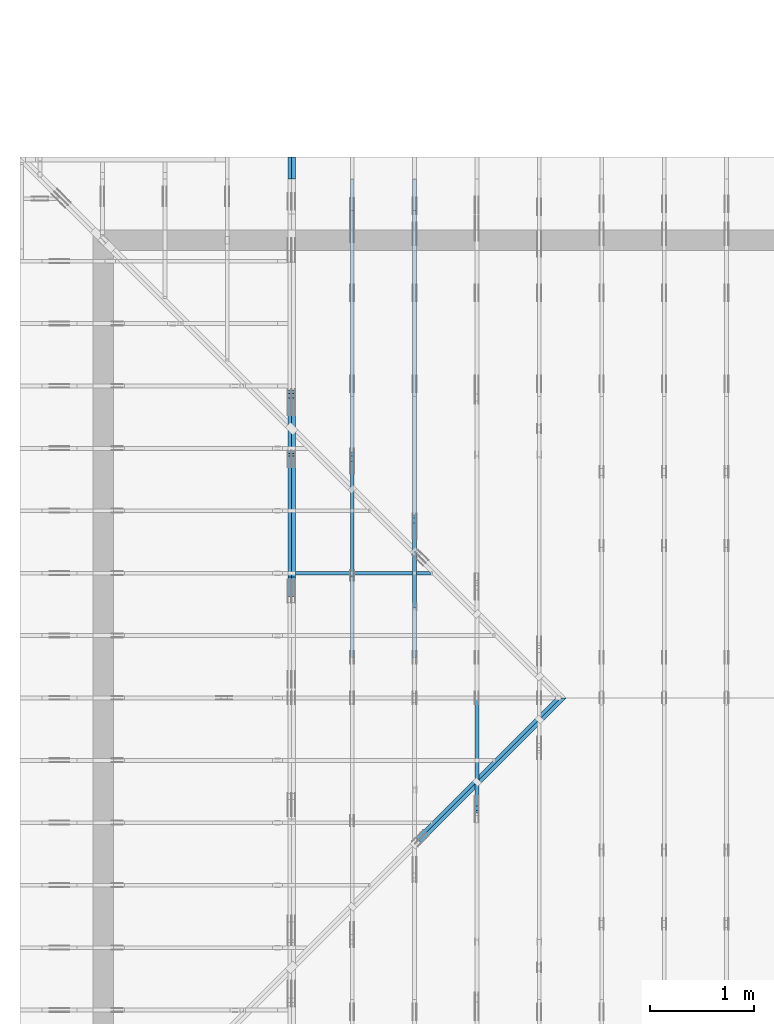
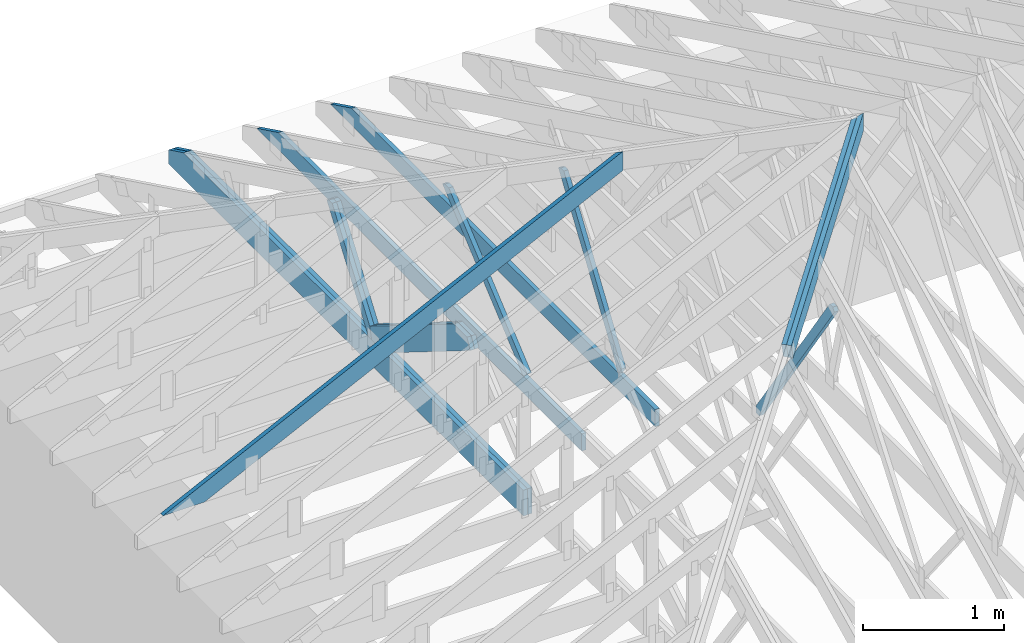
# One storey, part 8 of 159: 14 members, 6 elements without a shape of their own.
"""IFC2X3 building model written with IfcOpenShell, lengths in millimetres."""

from ifc_helpers import new_model, si_unit, frame, origin, origin_with_axes, origin_2d, place, context, project, spatial, faceted_brep, element, aggregate, save


model = new_model("IFC2X3")

# Units and contexts
model_context = context("Model", 3, precision=1e-05, world=origin())
plan_context = context("Plan", 2, precision=1e-05, world=origin_2d())
ifc_project = project(units=[si_unit("LENGTHUNIT", "METRE", prefix="MILLI"), si_unit("AREAUNIT", "SQUARE_METRE"), si_unit("VOLUMEUNIT", "CUBIC_METRE"), si_unit("SOLIDANGLEUNIT", "STERADIAN"), si_unit("PLANEANGLEUNIT", "RADIAN"), si_unit("MASSUNIT", "GRAM"), si_unit("TIMEUNIT", "SECOND"), si_unit("THERMODYNAMICTEMPERATUREUNIT", "DEGREE_CELSIUS"), si_unit("LUMINOUSINTENSITYUNIT", "LUMEN")], contexts=[model_context, plan_context])

# Site, building, storey
site_placement = place(None, origin_with_axes())
site = spatial("IfcSite", under=ifc_project, at=site_placement, CompositionType="ELEMENT")
building_placement = place(site_placement, origin_with_axes())
building = spatial("IfcBuilding", under=site, at=building_placement, Name="Plan 1", CompositionType="ELEMENT")
storey_placement = place(building_placement, origin_with_axes())
storey = spatial("IfcBuildingStorey", under=building, at=storey_placement, Name="Etasje 1", CompositionType="ELEMENT", Elevation=0.0)

# Assembly, member
assembly_1_placement = place(storey_placement, frame((-700.000000000007, 5681.993668449246, 1.1021457184401395e-15), z_axis=(0.0, -1.0, 6.123031769111886e-17), x_axis=(1.0, 0.0, 0.0)))
assembly_1 = element("IfcElementAssembly", 1, at=assembly_1_placement, inside=storey, Name="S3 (13)", AssemblyPlace="FACTORY", PredefinedType="TRUSS")
member_1_placement = place(assembly_1_placement, frame((276.0602225691233, 89.97847976265317, -36.00000021758854), z_axis=(0.0, 0.0, 1.0), x_axis=(0.898794046299167, 0.4383711467890774, 0.0)))
member_1 = element("IfcMember", 2, at=member_1_placement, Name="S3-O20", context=model_context, shape_type="Brep", body=[
    faceted_brep([(4178.836482823229, 147.99999481742884, 36.00000324779785), (4106.652058872152, 7.195239959401079e-10, 36.000000217589104), (4066.5983889296263, 3.219023483325145e-07, 6.821210263296962e-13), (4138.782812880701, 147.99999513861133, 3.03020965475298e-06), (5.61982989779608e-05, 147.99999999999778, 2.175885427391222e-07), (5.61982989779608e-05, 147.99999999999778, 36.00000021758854), (4178.836481979549, 147.99999999999753, 36.00000021758854), (4138.782813003719, 147.99999999999753, 2.175885427391222e-07), (9.727869428388658e-05, 148.0000000002397, 2.1758854273913412e-07), (4138.782812122445, 148.0000000002397, 2.1758904957709508e-07), (4066.5983867684413, 0.0, 2.175890407373445e-07), (303.44492149744434, 0.0, 2.175885798991801e-07), (303.4449717131312, 9.140421752817929e-11, 2.175885427391222e-07), (303.4449717131312, 9.140421752817929e-11, 36.00000021758854), (1.4210854715202004e-14, 148.00000154103162, 36.00000021758854), (1.4210854715202004e-14, 148.00000154103162, 2.175885427391222e-07), (4106.652057990875, 7.120212294089205e-10, 36.00000021758854), (303.44506870254423, 7.127198441255181e-10, 36.00000021758854), (303.44506870254423, 7.127176398340812e-10, 2.175885427391222e-07), (4066.598389015045, 7.120263826141119e-10, 2.175885427391222e-07), (4178.836484226156, 148.00000000071918, 36.00000021758854), (0.00020340340273605761, 148.00000000071918, 36.00000021758854), (303.4450276221526, 9.157474778476171e-11, 36.00000021758854), (4106.652058872153, 9.157474778476171e-11, 36.00000021758854)], [[[0, 1, 2, 3]], [[4, 5, 6, 7]], [[8, 9, 10, 11]], [[12, 13, 14, 15]], [[16, 17, 18, 19]], [[20, 21, 22, 23]]]),
])
aggregate(assembly_1, [member_1])

# Assembly, members
assembly_2_placement = place(storey_placement, frame((-674.5441558772914, -725.4547742521996, 2.204291436880279e-15), z_axis=(0.7071067811865475, -0.7071067811865476, 6.123031769111886e-17), x_axis=(0.7071067811865476, 0.7071067811865475, 0.0)))
assembly_2 = element("IfcElementAssembly", 3, at=assembly_2_placement, inside=storey, Name="GR1 (8)", AssemblyPlace="FACTORY", PredefinedType="TRUSS")
member_2_placement = place(assembly_2_placement, frame((5468.9344725271785, 1837.1506716808092, -36.00000195234122), z_axis=(0.0, 0.0, 1.0), x_axis=(0.9453579955214152, 0.32603413978252627, 0.0)))
member_2 = element("IfcMember", 4, at=member_2_placement, Name="GR1-O54.1", context=model_context, shape_type="Brep", body=[
    faceted_brep([(2083.0503962585176, 147.99999855201952, 36.00000161316632), (2032.0083021287878, 2.5398867364856414e-07, 36.00000195234111), (1993.9274905929392, 0.0, 2.3741075665384415e-06), (2044.9695847226685, 147.99999467122797, 3.217394123566919e-06), (0.00010423591174912872, 148.00000025499548, 1.952341222022369e-06), (0.00010423591174912872, 148.00000025499548, 36.00000195234122), (2083.0503972046617, 148.00000025499534, 36.00000195234122), (2044.9695866577858, 148.00000025499537, 1.952341222022369e-06), (0.00010288836620020447, 148.0000002568056, 1.9523412220223817e-06), (2044.969585310242, 148.0000002568056, 1.952341472450644e-06), (1993.927490125916, 2.550277713453397e-07, 1.9523414661999965e-06), (0.00010288836710969917, 2.550277713453397e-07, 1.9523412220223817e-06), (5.1431408792268485e-05, 6.324755759123946e-07, 1.8783537143463036e-06), (5.143140788320172e-05, 6.324755759123946e-07, 36.00000195234122), (5.143140790132588e-05, 148.000003407725, 36.00000255341424), (5.1431408810392706e-05, 148.000003407725, 4.576700956714107e-28), (2032.008300781249, 2.540408259103419e-07, 36.00000195234122), (4.049084566054305e-31, 2.540411991718833e-07, 36.00000195234122), (6.465218929522581e-38, 2.5404119696759185e-07, 1.952341222022369e-06), (1993.927490234374, 2.540408307011508e-07, 1.952341222022369e-06), (2083.0503973131126, 148.00000025398867, 36.00000195234122), (1.3475364539772272e-06, 148.00000025398867, 36.00000195234122), (1.3475364539772272e-06, 2.5680515136627946e-07, 36.00000195234122), (2032.0083021287874, 2.5680515136627946e-07, 36.00000195234122)], [[[0, 1, 2, 3]], [[4, 5, 6, 7]], [[8, 9, 10, 11]], [[12, 13, 14, 15]], [[16, 17, 18, 19]], [[20, 21, 22, 23]]]),
])
member_3_placement = place(assembly_2_placement, frame((5468.934471253672, 1837.1506712415073, -72.00000195234122), z_axis=(0.0, 0.0, 1.0), x_axis=(0.9453579955214152, 0.32603413978252627, 0.0)))
member_3 = element("IfcMember", 5, at=member_3_placement, Name="GR1-O54.1", context=model_context, shape_type="Brep", body=[
    faceted_brep([(2044.969585711107, 147.99999855221392, 36.00000161290052), (1993.9274915815217, 2.5413226012460655e-07, 36.00000195234111), (1955.846680045794, -5.684341886080802e-14, 2.3739810330880573e-06), (2006.8887741753783, 147.99999467127776, 3.2170017902899417e-06), (0.00010423551429994404, 148.00000025511963, 1.952341222022369e-06), (0.00010423551429994404, 148.00000025511918, 36.00000195234122), (2044.9695866573893, 148.00000025511903, 36.00000195234122), (2006.8887761105143, 148.00000025511952, 1.952341222022369e-06), (0.00010288836074323626, 148.00000025689633, 1.9523412220223817e-06), (2006.8887747633617, 148.00000025689633, 1.9523414677872435e-06), (1955.8466795790346, 2.551523721194826e-07, 1.952341461536596e-06), (0.00010288836165273096, 2.551523721194826e-07, 1.9523412220223817e-06), (5.277855598251335e-05, 6.325665253825719e-07, 1.8783537143463036e-06), (5.2778555073446586e-05, 6.325665253825719e-07, 36.00000195234122), (5.2778555091570747e-05, 148.00000340781594, 36.00000255341424), (5.2778556000637575e-05, 148.00000340781594, 4.576700956714107e-28), (1993.927490234376, 2.5418498781567277e-07, 36.00000195234122), (9.094947017729282e-13, 2.541853540821138e-07, 36.00000195234122), (9.094947017729282e-13, 2.541853518778224e-07, 1.952341222022369e-06), (1955.846679687501, 2.5418499260648175e-07, 1.952341222022369e-06), (2044.9695867658475, 148.00000025413283, 36.00000195234122), (1.3471462807501666e-06, 148.00000025413283, 36.00000195234122), (1.3471462807501666e-06, 2.5689610083645675e-07, 36.00000195234122), (1993.9274915815213, 2.5689610083645675e-07, 36.00000195234122)], [[[0, 1, 2, 3]], [[4, 5, 6, 7]], [[8, 9, 10, 11]], [[12, 13, 14, 15]], [[16, 17, 18, 19]], [[20, 21, 22, 23]]]),
])
aggregate(assembly_2, [member_2, member_3])

# Assembly, member
assembly_3_placement = place(storey_placement, frame((3675.02226140475, 9699.999999999993, 1.1021457184401395e-15), z_axis=(-1.0, 1.836909530733566e-16, 6.123031769111886e-17), x_axis=(-1.836909530733566e-16, -1.0, 0.0)))
assembly_3 = element("IfcElementAssembly", 6, at=assembly_3_placement, inside=storey, Name="V4 (5)", AssemblyPlace="FACTORY", PredefinedType="TRUSS")
member_4_placement = place(assembly_3_placement, frame((6252.472090234662, 1961.8934703465848, -36.00000000000001), z_axis=(0.0, 0.0, 1.0), x_axis=(-0.567606162978192, -0.8233002148361037, 0.0)))
member_4 = element("IfcMember", 7, at=member_4_placement, Name="V4-D17", context=model_context, shape_type="Brep", body=[
    faceted_brep([(1882.0088922396953, 72.99981526764714, 36.0), (11.925045841840074, 72.99981526764714, 36.0), (1.7729007595335133e-06, 36.49989538157706, 36.0), (25.163967382082774, 0.00011852315719806938, 36.0), (1854.2304179382295, 0.00011852315719806938, 36.0), (1907.1728578488774, 36.49989538157706, 36.0), (11.925045841840074, 72.99981526764714, 1.4603486907540475e-15), (1882.0088922396953, 72.99981526764714, 2.3047200473869444e-13), (1907.1728578488774, 36.49989538157706, 2.335535999559317e-13), (1854.2304179382295, 0.00011852315719806938, 2.270702351257878e-13), (25.163967382082774, 0.00011852315719806938, 3.0815954343477618e-15), (1.7729007595335133e-06, 36.49989538157706, 2.171105534821259e-22), (-3.552713678800501e-15, 36.50000000000729, 3.0412819459963817e-31), (-1.7763568394002505e-15, 36.50000000000729, 36.0), (11.924987637653432, 72.9999999999991, 36.0), (11.924987637653429, 72.9999999999991, 5.210607437362237e-31), (25.164119449224014, -3.552713678800501e-15, 3.944304526105059e-31), (25.164119449224017, -1.7763568394002505e-15, 36.0), (1.4210854715202004e-14, 36.50000000000728, 36.0), (1.0658141036401503e-14, 36.50000000000728, -7.888609052210118e-31), (1854.2304397233015, 1.2875129933782132e-12, 4.698144675927301e-30), (1854.2304397233015, 1.2897172848150934e-12, 36.0), (25.164119449224017, 1.1629865528625666e-15, 36.0), (25.164119449224017, -1.0413048840177125e-15, 6.375942886171814e-32), (1907.1728843292735, 36.499999999997385, 3.7865323450608567e-29), (1907.1728843292735, 36.499999999997385, 36.0), (1854.230439723302, 6.821210263296962e-13, 36.0), (1854.230439723302, 6.821210263296962e-13, 3.7865323450608567e-29), (1882.0087648800502, 73.00000000000159, -1.9030413559702196e-29), (1882.0087648800502, 73.00000000000159, 36.0), (1907.172884329273, 36.49999999999784, 36.0), (1907.172884329273, 36.49999999999784, -1.8757185624799696e-29), (11.92498763765343, 72.99999999999909, 0.0), (11.92498763765343, 72.99999999999909, 36.0), (1882.0087648800504, 73.00000000000189, 36.0), (1882.0087648800504, 73.00000000000189, 3.944304526105059e-30)], [[[0, 1, 2, 3, 4, 5]], [[6, 7, 8, 9, 10, 11]], [[12, 13, 14, 15]], [[16, 17, 18, 19]], [[20, 21, 22, 23]], [[24, 25, 26, 27]], [[28, 29, 30, 31]], [[32, 33, 34, 35]]]),
])
aggregate(assembly_3, [member_4])

# Assembly, members
assembly_4_placement = place(storey_placement, frame((3075.02226140475, 9699.999999999993, 1.1021457184401395e-15), z_axis=(-1.0, 1.836909530733566e-16, 6.123031769111886e-17), x_axis=(-1.836909530733566e-16, -1.0, 0.0)))
assembly_4 = element("IfcElementAssembly", 8, at=assembly_4_placement, inside=storey, Name="V3 (4)", AssemblyPlace="FACTORY", PredefinedType="TRUSS")
member_5_placement = place(assembly_4_placement, frame((4808.81787109375, 371.00000000000045, -36.0), z_axis=(0.0, 0.0, 1.0), x_axis=(-1.0, 1.2246063538223773e-16, 0.0)))
member_5 = element("IfcMember", 9, at=member_5_placement, Name="V3-U35", context=model_context, shape_type="Brep", body=[
    faceted_brep([(4597.636581420898, 148.000000000001, 36.0), (0.0, 148.000000000001, 36.0), (0.0, 4.547473508864641e-13, 36.0), (4294.191589355469, 4.547473508864641e-13, 36.0), (0.0, 148.000000000001, 0.0), (4597.636581420898, 148.000000000001, 5.630294970174226e-13), (4294.191589355469, 4.547473508864641e-13, 5.25869430485532e-13), (0.0, 4.547473508864641e-13, 0.0), (0.00023664720265514916, 0.0, 0.0), (0.00023664720265735345, -2.6993892992798474e-31, 36.0), (0.00023664720267547762, 147.99999999999997, 36.0), (0.00023664720267327333, 147.99999999999997, -1.1097479173457682e-30), (4294.191606856883, -7.888042021967641e-13, 1.0746792202003985e-28), (4294.191606856883, -7.865999107598839e-13, 36.0), (0.00023664720265514916, 2.2041947133152905e-15, 36.0), (0.00023664720265514916, -9.672356498864107e-20, 5.922414612472074e-36), (4597.636575412006, 148.00000000000205, -2.5243548967072372e-29), (4597.636575412006, 148.00000000000205, 36.0), (4294.191606856883, 1.5916157281026244e-12, 36.0), (4294.191606856883, 1.5916157281026244e-12, -2.5243548967072372e-29), (0.00023664720265514916, 147.99999999999997, 0.0), (0.00023664720265514916, 147.99999999999997, 36.0), (4597.636575412005, 148.0000000000007, 36.0), (4597.636575412005, 148.0000000000007, -1.735493991486226e-29)], [[[0, 1, 2, 3]], [[4, 5, 6, 7]], [[8, 9, 10, 11]], [[12, 13, 14, 15]], [[16, 17, 18, 19]], [[20, 21, 22, 23]]]),
])
member_6_placement = place(assembly_4_placement, frame((3438.4424404888405, 1632.3753621443234, -35.99999999999999), z_axis=(0.0, 0.0, 1.0), x_axis=(0.5603073033844749, -0.8282848095757992, 0.0)))
member_6 = element("IfcMember", 10, at=member_6_placement, Name="V3-D30", context=model_context, shape_type="Brep", body=[
    faceted_brep([(1493.610833894492, 73.00034285986249, 36.0), (29.87093653177908, 73.00034285986249, 36.0), (5.179933688446226, 36.500243712163865, 36.0), (0.0, 0.0002251209748465044, 36.0), (1522.8763675991224, 0.0002251209748465044, 36.0), (29.87093653177908, 73.00034285986249, 3.658013867144162e-15), (1493.610833894492, 73.00034285986249, 1.8290853173251343e-13), (1522.8763675991224, 0.0002251209748465044, 1.8649240758478276e-13), (0.0, 0.0002251209748465044, 0.0), (5.179933688446226, 36.500243712163865, 6.343379707249831e-16), (5.179846854619438, 36.50018205388142, -3.944304526105059e-31), (5.179846854619441, 36.50018205388142, 36.0), (29.870890727174366, 73.000182051514, 36.0), (29.870890727174366, 73.000182051514, -5.9164567891575885e-31), (4.145090724708039e-05, 0.00018205151400251988, -1.651522543131281e-33), (4.145090724926282e-05, 0.00018205151400221017, 36.0), (5.1798468546194325, 36.50018205388142, 36.0), (5.179846854619431, 36.50018205388142, -2.564377601742566e-31), (1522.876490750957, 0.00018205151507537097, 4.568651442233575e-29), (1522.876490750957, 0.00018205151507757526, 36.0), (4.145090724705369e-05, 0.00018205151400472788, 36.0), (4.145090724705369e-05, 0.0001820515140025236, 1.504632769052528e-36), (1493.6107231272665, 73.00018205151548, 1.5038639598628418e-30), (1493.6107231272665, 73.00018205151548, 36.0), (1522.876490750957, 0.00018205151593519986, 36.0), (1522.876490750957, 0.00018205151593519986, 1.7462163754190554e-30), (29.87089072717436, 73.000182051514, 0.0), (29.87089072717436, 73.000182051514, 36.0), (1493.6107231272665, 73.00018205151554, 36.0), (1493.6107231272665, 73.00018205151554, 1.1044052673094165e-29)], [[[0, 1, 2, 3, 4]], [[5, 6, 7, 8, 9]], [[10, 11, 12, 13]], [[14, 15, 16, 17]], [[18, 19, 20, 21]], [[22, 23, 24, 25]], [[26, 27, 28, 29]]]),
])
aggregate(assembly_4, [member_5, member_6])

assembly_5_placement = place(storey_placement, frame((2475.02226140475, 9699.999999999993, 1.1021457184401395e-15), z_axis=(-1.0, 1.836909530733566e-16, 6.123031769111886e-17), x_axis=(-1.836909530733566e-16, -1.0, 0.0)))
assembly_5 = element("IfcElementAssembly", 11, at=assembly_5_placement, inside=storey, Name="V2 (3)", AssemblyPlace="FACTORY", PredefinedType="TRUSS")
member_7_placement = place(assembly_5_placement, frame((4808.81787109375, 371.0, -36.0), z_axis=(0.0, 0.0, 1.0), x_axis=(-1.0, 1.2246063538223773e-16, 0.0)))
member_7 = element("IfcMember", 12, at=member_7_placement, Name="V2-U35", context=model_context, shape_type="Brep", body=[
    faceted_brep([(4597.636581420898, 148.00000000000054, 36.0), (0.0, 148.00000000000054, 36.0), (0.0, 0.0, 36.0), (4294.191589355469, 0.0, 36.0), (0.0, 148.00000000000054, 0.0), (4597.636581420898, 148.00000000000054, 5.630294970174226e-13), (4294.191589355469, 0.0, 5.25869430485532e-13), (0.0, 0.0, 0.0), (0.00023664720356464386, 0.0, 0.0), (0.00023664720356684815, -2.6993892992798474e-31, 36.0), (0.00023664720358497233, 147.99999999999997, 36.0), (0.00023664720358276803, 147.99999999999997, -1.1097479173457682e-30), (4294.191606856883, -7.888041771362396e-13, 7.962359572160306e-29), (4294.191606856883, -7.865998856993593e-13, 36.0), (0.00023664720356464386, 2.2042197738396225e-15, 36.0), (0.00023664720356464386, -7.166304065663759e-20, 4.387950746117487e-36), (4597.636575412005, 148.0000000000009, -2.5243548967072372e-29), (4597.636575412005, 148.0000000000009, 36.0), (4294.191606856883, 9.094947017729282e-13, 36.0), (4294.191606856883, 9.094947017729282e-13, -2.5243548967072372e-29), (0.00023664720356464386, 147.99999999999997, 0.0), (0.00023664720356464386, 147.99999999999997, 36.0), (4597.636575412005, 148.0000000000007, 36.0), (4597.636575412005, 148.0000000000007, 1.1044052673094165e-29)], [[[0, 1, 2, 3]], [[4, 5, 6, 7]], [[8, 9, 10, 11]], [[12, 13, 14, 15]], [[16, 17, 18, 19]], [[20, 21, 22, 23]]]),
])
member_8_placement = place(assembly_5_placement, frame((2835.7304687500005, 1338.4130859375, -36.00000000000001), z_axis=(0.0, 0.0, 1.0), x_axis=(0.7634525540161362, -0.6458639158261117, 0.0)))
member_8 = element("IfcMember", 13, at=member_8_placement, Name="V2-D31", context=model_context, shape_type="Brep", body=[
    faceted_brep([(1510.1262624601582, 73.00006736832302, 36.0), (59.22069243180658, 73.00006736832302, 36.0), (16.075371691791588, 36.5001661737283, 36.0), (0.0, 0.0, 36.0), (1497.8591223631006, 0.0, 36.0), (59.22069243180658, 73.00006736832302, 7.252203622975112e-15), (1510.1262624601582, 73.00006736832302, 1.8493102160827485e-13), (1497.8591223631006, 0.0, 1.8342877983766626e-13), (0.0, 0.0, 0.0), (16.075371691791588, 36.5001661737283, 1.9686002313824358e-15), (16.0752887080489, 36.5001098598309, 0.0), (16.0752887080489, 36.5001098598309, 36.0), (59.22062867497106, 73.00010985864765, 36.0), (59.22062867497106, 73.00010985864765, 3.944304526105059e-31), (5.931443138357624e-05, 0.00010985864719212936, -7.081601879689162e-32), (5.9314431385593556e-05, 0.0001098586471912409, 36.0), (16.075288708048877, 36.50010985983091, 36.0), (16.075288708048873, 36.50010985983091, 1.5062443203767112e-30), (1497.8591404537046, 0.00010985864558708625, 1.4772869712546597e-29), (1497.8591404537046, 0.00010985864558929054, 36.0), (5.93144313825178e-05, 0.0001098586471947998, 36.0), (5.93144313825178e-05, 0.00010985864719259551, 7.52316384526264e-37), (1510.1262905414742, 73.0001098586458, -1.2621774483536186e-29), (1510.1262905414742, 73.0001098586458, 36.0), (1497.8591404537046, 0.00010985864579993176, 36.0), (1497.8591404537046, 0.00010985864579993176, -1.2621774483536186e-29), (59.22062867497107, 73.00010985864765, 7.888609052210118e-31), (59.22062867497107, 73.00010985864765, 36.0), (1510.1262905414742, 73.00010985864594, 36.0), (1510.1262905414742, 73.00010985864596, 7.888609052210118e-30)], [[[0, 1, 2, 3, 4]], [[5, 6, 7, 8, 9]], [[10, 11, 12, 13]], [[14, 15, 16, 17]], [[18, 19, 20, 21]], [[22, 23, 24, 25]], [[26, 27, 28, 29]]]),
])
aggregate(assembly_5, [member_7, member_8])

assembly_6_placement = place(storey_placement, frame((1875.0222614047502, 9699.999999999993, 0.0), z_axis=(-1.0, 1.836909530733566e-16, 6.123031769111886e-17), x_axis=(-1.836909530733566e-16, -1.0, 0.0)))
assembly_6 = element("IfcElementAssembly", 14, at=assembly_6_placement, inside=storey, Name="V1 (2)", AssemblyPlace="FACTORY", PredefinedType="TRUSS")
member_9_placement = place(assembly_6_placement, frame((5019.9990234375, 223.00000000093073, -36.0), z_axis=(0.0, 0.0, 1.0), x_axis=(-1.0, 1.2246063538223773e-16, 0.0)))
member_9 = element("IfcMember", 15, at=member_9_placement, Name="V1-U4", context=model_context, shape_type="Brep", body=[
    faceted_brep([(5019.9990234375, 223.00000000093135, 36.0), (0.0, 223.00000000093135, 36.0), (0.0, 9.3072571871744e-10, 36.0), (4808.817733764648, 9.3072571871744e-10, 36.0), (5019.999023437502, 103.00000000093135, 36.0), (0.0, 223.00000000093135, 0.0), (5019.9990234375, 223.00000000093135, 6.147522700283691e-13), (5019.999023437502, 103.00000000093135, 6.147522700283693e-13), (4808.817733764648, 9.3072571871744e-10, 5.888908751141913e-13), (0.0, 9.3072571871744e-10, 0.0), (0.00012207031977595761, 9.306972970080096e-10, 0.0), (0.0001220703197781619, 9.306972970080096e-10, 36.0), (0.00012207031980547063, 223.00000000093073, 36.0), (0.00012207031980326634, 223.00000000093073, -1.67212096573961e-30), (4808.8177277538925, -1.2832280317029862e-12, 7.857246005132692e-29), (4808.8177277538925, -1.281023740266106e-12, 36.0), (0.00012207031977595761, 9.306995012668721e-10, 36.0), (0.00012207031977595761, 9.306972969754353e-10, 1.994540702744352e-36), (5019.9990234375, 103.0000000007442, -1.3741865306144549e-28), (5019.9990234375, 103.0000000007442, 36.0), (4808.817727753891, 2.0463630789890885e-12, 36.0), (4808.817727753891, 2.0463630789890885e-12, -1.381426816777479e-28), (5019.999023437504, 223.00000000093135, 2.0194839173657902e-28), (5019.999023437504, 223.00000000093135, 36.0), (5019.999023437504, 103.00000000074218, 36.0), (5019.999023437504, 103.00000000074218, 1.0097419586828951e-28), (0.00012207031977595761, 223.00000000093073, 0.0), (0.00012207031977595761, 223.00000000093073, 36.0), (5019.9990234375, 223.00000000093152, 36.0), (5019.9990234375, 223.00000000093152, 1.1044052673094165e-29)], [[[0, 1, 2, 3, 4]], [[5, 6, 7, 8, 9]], [[10, 11, 12, 13]], [[14, 15, 16, 17]], [[18, 19, 20, 21]], [[22, 23, 24, 25]], [[26, 27, 28, 29]]]),
])
member_10_placement = place(assembly_6_placement, frame((5019.9990234375, 223.00000000093073, -72.0), z_axis=(0.0, 0.0, 1.0), x_axis=(-1.0, 1.2246063538223773e-16, 0.0)))
member_10 = element("IfcMember", 16, at=member_10_placement, Name="V1-U4", context=model_context, shape_type="Brep", body=[
    faceted_brep([(5019.9990234375, 223.00000000093135, 36.0), (0.0, 223.00000000093135, 36.0), (0.0, 9.3072571871744e-10, 36.0), (4808.817733764648, 9.3072571871744e-10, 36.0), (5019.999023437502, 103.00000000093135, 36.0), (0.0, 223.00000000093135, 0.0), (5019.9990234375, 223.00000000093135, 6.147522700283691e-13), (5019.999023437502, 103.00000000093135, 6.147522700283693e-13), (4808.817733764648, 9.3072571871744e-10, 5.888908751141913e-13), (0.0, 9.3072571871744e-10, 0.0), (0.00012207031977595761, 9.306972970080096e-10, 0.0), (0.0001220703197781619, 9.306972970080096e-10, 36.0), (0.00012207031980547063, 223.00000000093073, 36.0), (0.00012207031980326634, 223.00000000093073, -1.67212096573961e-30), (4808.8177277538925, -1.2832280317029862e-12, 7.857246005132692e-29), (4808.8177277538925, -1.281023740266106e-12, 36.0), (0.00012207031977595761, 9.306995012668721e-10, 36.0), (0.00012207031977595761, 9.306972969754353e-10, 1.994540702744352e-36), (5019.9990234375, 103.0000000007442, -1.3741865306144549e-28), (5019.9990234375, 103.0000000007442, 36.0), (4808.817727753891, 2.0463630789890885e-12, 36.0), (4808.817727753891, 2.0463630789890885e-12, -1.381426816777479e-28), (5019.999023437504, 223.00000000093135, 2.0194839173657902e-28), (5019.999023437504, 223.00000000093135, 36.0), (5019.999023437504, 103.00000000074218, 36.0), (5019.999023437504, 103.00000000074218, 1.0097419586828951e-28), (0.00012207031977595761, 223.00000000093073, 0.0), (0.00012207031977595761, 223.00000000093073, 36.0), (5019.9990234375, 223.00000000093152, 36.0), (5019.9990234375, 223.00000000093152, 1.1044052673094165e-29)], [[[0, 1, 2, 3, 4]], [[5, 6, 7, 8, 9]], [[10, 11, 12, 13]], [[14, 15, 16, 17]], [[18, 19, 20, 21]], [[22, 23, 24, 25]], [[26, 27, 28, 29]]]),
])
member_11_placement = place(assembly_6_placement, frame((2238.299776386544, 1047.0266507762, -36.0), z_axis=(0.0, 0.0, 1.0), x_axis=(0.5829248698653031, -0.812526058715977, 0.0)))
member_11 = element("IfcMember", 17, at=member_11_placement, Name="V1-D50", context=model_context, shape_type="Brep", body=[
    faceted_brep([(943.5187391608237, 73.00003591286895, 36.0), (32.39653997347182, 73.00003591286895, 36.0), (6.210604150633571, 36.500122374111925, 36.0), (4.854991993852309e-05, 0.0, 36.0), (1014.1542086821188, 0.0, 36.0), (1040.3401445049572, 36.500122374111925, 36.0), (32.39653997347182, 73.00003591286895, 3.967300869337422e-15), (943.5187391608237, 73.00003591286895, 1.155439042926823e-13), (1040.3401445049572, 36.500122374111925, 1.2740071510972605e-13), (1014.1542086821188, 0.0, 1.2419396877078278e-13), (4.854991993852309e-05, 0.0, 5.9454540434283095e-21), (6.210604150633571, 36.500122374111925, 7.6055453039415e-16), (6.21055915533611, 36.500031918273635, 0.0), (6.210559155336114, 36.500031918273635, 36.0), (32.39649808198372, 73.00003191786709, 36.0), (32.39649808198372, 73.00003191786709, 5.9164567891575885e-31), (6.089573967695341e-17, 3.1917867090659106e-05, -3.7822236034317594e-33), (2.2339545306931247e-15, 3.191786709028935e-05, 36.0), (6.210559155336124, 36.500031918273635, 36.0), (6.210559155336123, 36.500031918273635, -5.131400065774482e-31), (1014.1541437863892, 3.19178660036287e-05, 1.087120196521818e-29), (1014.1541437863892, 3.191786600583299e-05, 36.0), (2.3627128001810323e-30, 3.191786709287375e-05, 36.0), (0.0, 3.191786709066946e-05, 0.0), (1040.340082713263, 36.500031917894205, 1.262177448353619e-29), (1040.340082713263, 36.500031917894205, 36.0), (1014.1541437863893, 3.191786606748792e-05, 36.0), (1014.1541437863893, 3.191786606748792e-05, 1.8932661725304283e-29), (943.5187413743206, 73.00003191786578, 3.669693188441447e-30), (943.5187413743206, 73.00003191786578, 36.0), (1040.3400827132627, 36.50003191789443, 36.0), (1040.3400827132627, 36.50003191789443, 1.9539935845288751e-31), (32.39649808198374, 73.00003191786709, 0.0), (32.39649808198374, 73.00003191786709, 36.0), (943.5187413743207, 73.00003191786602, 36.0), (943.5187413743207, 73.00003191786602, 1.8143800820083272e-29)], [[[0, 1, 2, 3, 4, 5]], [[6, 7, 8, 9, 10, 11]], [[12, 13, 14, 15]], [[16, 17, 18, 19]], [[20, 21, 22, 23]], [[24, 25, 26, 27]], [[28, 29, 30, 31]], [[32, 33, 34, 35]]]),
])
member_12_placement = place(assembly_6_placement, frame((2238.299776386544, 1047.0266507762, -72.0), z_axis=(0.0, 0.0, 1.0), x_axis=(0.5829248698653031, -0.812526058715977, 0.0)))
member_12 = element("IfcMember", 18, at=member_12_placement, Name="V1-D50", context=model_context, shape_type="Brep", body=[
    faceted_brep([(943.5187391608237, 73.00003591286895, 36.0), (32.39653997347182, 73.00003591286895, 36.0), (6.210604150633571, 36.500122374111925, 36.0), (4.854991993852309e-05, 0.0, 36.0), (1014.1542086821188, 0.0, 36.0), (1040.3401445049572, 36.500122374111925, 36.0), (32.39653997347182, 73.00003591286895, 3.967300869337422e-15), (943.5187391608237, 73.00003591286895, 1.155439042926823e-13), (1040.3401445049572, 36.500122374111925, 1.2740071510972605e-13), (1014.1542086821188, 0.0, 1.2419396877078278e-13), (4.854991993852309e-05, 0.0, 5.9454540434283095e-21), (6.210604150633571, 36.500122374111925, 7.6055453039415e-16), (6.21055915533611, 36.500031918273635, 0.0), (6.210559155336114, 36.500031918273635, 36.0), (32.39649808198372, 73.00003191786709, 36.0), (32.39649808198372, 73.00003191786709, 5.9164567891575885e-31), (6.089573967695341e-17, 3.1917867090659106e-05, -3.7822236034317594e-33), (2.2339545306931247e-15, 3.191786709028935e-05, 36.0), (6.210559155336124, 36.500031918273635, 36.0), (6.210559155336123, 36.500031918273635, -5.131400065774482e-31), (1014.1541437863892, 3.19178660036287e-05, 1.087120196521818e-29), (1014.1541437863892, 3.191786600583299e-05, 36.0), (2.3627128001810323e-30, 3.191786709287375e-05, 36.0), (0.0, 3.191786709066946e-05, 0.0), (1040.340082713263, 36.500031917894205, 1.262177448353619e-29), (1040.340082713263, 36.500031917894205, 36.0), (1014.1541437863893, 3.191786606748792e-05, 36.0), (1014.1541437863893, 3.191786606748792e-05, 1.8932661725304283e-29), (943.5187413743206, 73.00003191786578, 3.669693188441447e-30), (943.5187413743206, 73.00003191786578, 36.0), (1040.3400827132627, 36.50003191789443, 36.0), (1040.3400827132627, 36.50003191789443, 1.9539935845288751e-31), (32.39649808198374, 73.00003191786709, 0.0), (32.39649808198374, 73.00003191786709, 36.0), (943.5187413743207, 73.00003191786602, 36.0), (943.5187413743207, 73.00003191786602, 1.8143800820083272e-29)], [[[0, 1, 2, 3, 4, 5]], [[6, 7, 8, 9, 10, 11]], [[12, 13, 14, 15]], [[16, 17, 18, 19]], [[20, 21, 22, 23]], [[24, 25, 26, 27]], [[28, 29, 30, 31]], [[32, 33, 34, 35]]]),
])
member_13_placement = place(assembly_6_placement, frame((4171.5303637128645, 1147.2973450235172, -36.0), z_axis=(0.0, 0.0, 1.0), x_axis=(-0.8488894687856868, -0.5285704019189448, 0.0)))
member_13 = element("IfcMember", 19, at=member_13_placement, Name="V1-D2", context=model_context, shape_type="Brep", body=[
    faceted_brep([(1430.683920712328, 198.0000650427014, 36.0), (7.277290912928947, 198.0000650427014, 36.0), (0.0, 99.00010067894573, 36.0), (158.99517371759157, 0.0, 36.0), (1559.5854168918113, 0.0, 36.0), (1589.6788871815138, 99.00010067894573, 36.0), (7.277290912928947, 198.0000650427014, 8.911816690586638e-16), (1430.683920712328, 198.0000650427014, 1.752024619615827e-13), (1589.6788871815138, 99.00010067894573, 1.9467308657797678e-13), (1559.5854168918113, 0.0, 1.9098782108544331e-13), (158.99517371759157, 0.0, 1.9470649996165528e-14), (0.0, 99.00010067894573, 0.0), (0.00013225016393292321, 99.00003737928546, -9.860761315262648e-31), (0.00013225016393469957, 99.00003737928546, 36.0), (7.277434146744822, 198.00003737928682, 36.0), (7.27743414674482, 198.00003737928682, -2.070759876205156e-30), (158.99514427633855, 3.737928729208306e-05, 4.159062164091937e-31), (158.99514427633855, 3.737928729208306e-05, 36.0), (0.00013225016390805422, 99.00003737928543, 36.0), (0.00013225016390805422, 99.00003737928542, 2.2053334536659353e-30), (1559.585420733592, 3.737928445331358e-05, 4.7649160791711596e-29), (1559.585420733592, 3.737928445551787e-05, 36.0), (158.99514427633858, 3.7379287200741754e-05, 36.0), (158.99514427633858, 3.737928719853746e-05, 4.857691848558396e-30), (1589.6789771649392, 99.0000373792866, 2.3526989162418842e-29), (1589.6789771649392, 99.0000373792866, 36.0), (1559.5854207335924, 3.7379285004135454e-05, 36.0), (1559.5854207335924, 3.7379285004135454e-05, 2.384583937152361e-29), (1430.6839651387904, 198.00003737929023, 9.730832201209172e-30), (1430.6839651387904, 198.00003737929023, 36.0), (1589.6789771649387, 99.00003737928682, 36.0), (1589.6789771649387, 99.00003737928682, 1.0307987679615405e-29), (7.277434146744781, 198.00003737928682, 0.0), (7.277434146744781, 198.00003737928682, 36.0), (1430.6839651387904, 198.0000373792902, 36.0), (1430.6839651387904, 198.0000373792902, -3.1554436208840472e-30)], [[[0, 1, 2, 3, 4, 5]], [[6, 7, 8, 9, 10, 11]], [[12, 13, 14, 15]], [[16, 17, 18, 19]], [[20, 21, 22, 23]], [[24, 25, 26, 27]], [[28, 29, 30, 31]], [[32, 33, 34, 35]]]),
])
member_14_placement = place(assembly_6_placement, frame((4171.5303637128645, 1147.2973450235172, -72.0), z_axis=(0.0, 0.0, 1.0), x_axis=(-0.8488894687856868, -0.5285704019189448, 0.0)))
member_14 = element("IfcMember", 20, at=member_14_placement, Name="V1-D2", context=model_context, shape_type="Brep", body=[
    faceted_brep([(1430.683920712328, 198.0000650427014, 36.0), (7.277290912928947, 198.0000650427014, 36.0), (0.0, 99.00010067894573, 36.0), (158.99517371759157, 0.0, 36.0), (1559.5854168918113, 0.0, 36.0), (1589.6788871815138, 99.00010067894573, 36.0), (7.277290912928947, 198.0000650427014, 8.911816690586638e-16), (1430.683920712328, 198.0000650427014, 1.752024619615827e-13), (1589.6788871815138, 99.00010067894573, 1.9467308657797678e-13), (1559.5854168918113, 0.0, 1.9098782108544331e-13), (158.99517371759157, 0.0, 1.9470649996165528e-14), (0.0, 99.00010067894573, 0.0), (0.00013225016393292321, 99.00003737928546, -9.860761315262648e-31), (0.00013225016393469957, 99.00003737928546, 36.0), (7.277434146744822, 198.00003737928682, 36.0), (7.27743414674482, 198.00003737928682, -2.070759876205156e-30), (158.99514427633855, 3.737928729208306e-05, 4.159062164091937e-31), (158.99514427633855, 3.737928729208306e-05, 36.0), (0.00013225016390805422, 99.00003737928543, 36.0), (0.00013225016390805422, 99.00003737928542, 2.2053334536659353e-30), (1559.585420733592, 3.737928445331358e-05, 4.7649160791711596e-29), (1559.585420733592, 3.737928445551787e-05, 36.0), (158.99514427633858, 3.7379287200741754e-05, 36.0), (158.99514427633858, 3.737928719853746e-05, 4.857691848558396e-30), (1589.6789771649392, 99.0000373792866, 2.3526989162418842e-29), (1589.6789771649392, 99.0000373792866, 36.0), (1559.5854207335924, 3.7379285004135454e-05, 36.0), (1559.5854207335924, 3.7379285004135454e-05, 2.384583937152361e-29), (1430.6839651387904, 198.00003737929023, 9.730832201209172e-30), (1430.6839651387904, 198.00003737929023, 36.0), (1589.6789771649387, 99.00003737928682, 36.0), (1589.6789771649387, 99.00003737928682, 1.0307987679615405e-29), (7.277434146744781, 198.00003737928682, 0.0), (7.277434146744781, 198.00003737928682, 36.0), (1430.6839651387904, 198.0000373792902, 36.0), (1430.6839651387904, 198.0000373792902, -3.1554436208840472e-30)], [[[0, 1, 2, 3, 4, 5]], [[6, 7, 8, 9, 10, 11]], [[12, 13, 14, 15]], [[16, 17, 18, 19]], [[20, 21, 22, 23]], [[24, 25, 26, 27]], [[28, 29, 30, 31]], [[32, 33, 34, 35]]]),
])
aggregate(assembly_6, [member_9, member_10, member_11, member_12, member_13, member_14])

save(model, "model.ifc")
